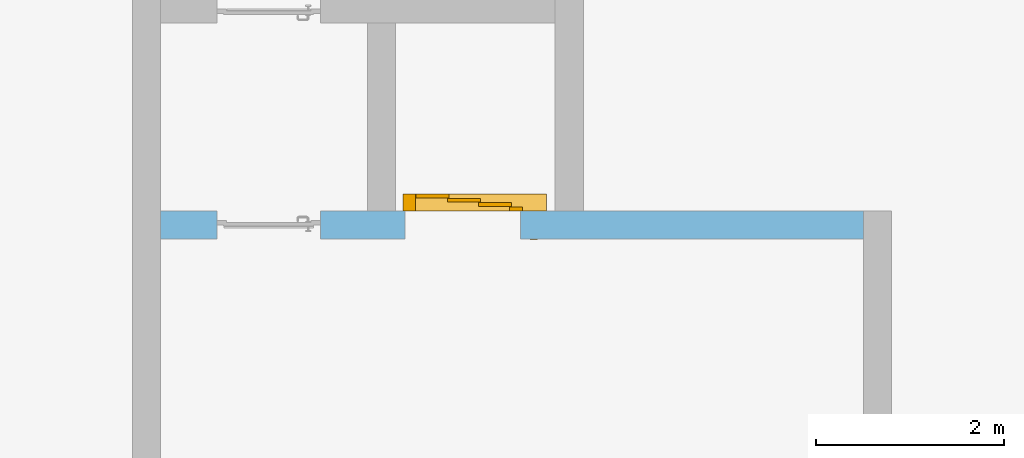
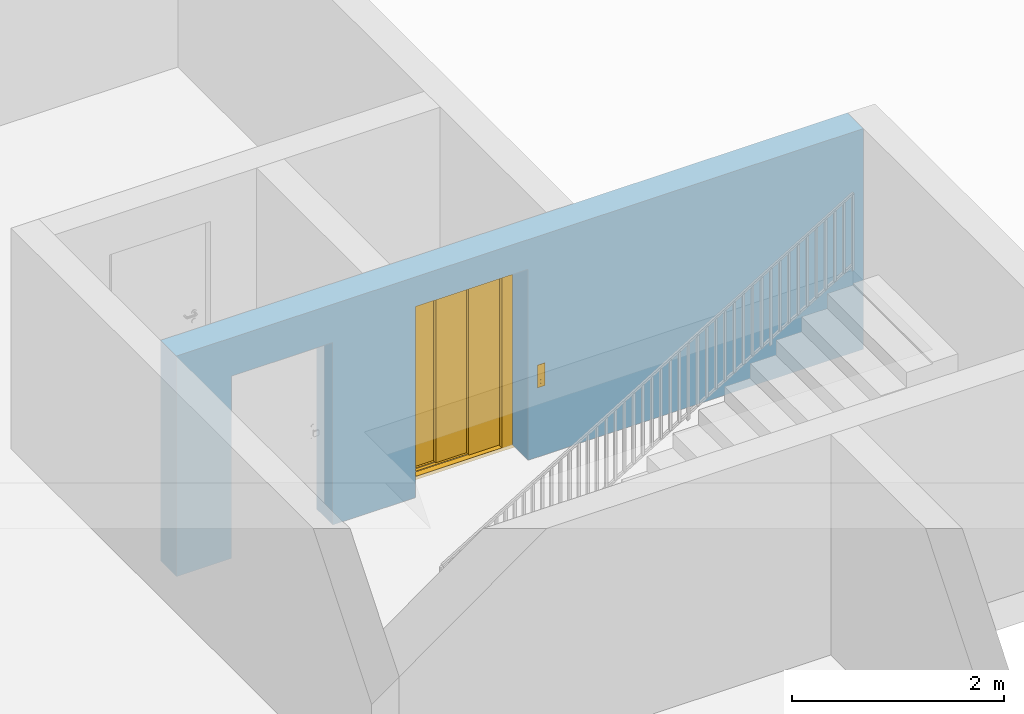
# One storey, part 4 of 6: 1 door, 2 openings, plus 1 element that does not belong to this part.
"""IFC4 building model written with IfcOpenShell, lengths in metres."""

from ifc_helpers import new_model, entity, si_unit, converted_unit, derived_unit, direction, frame, origin_with_axes, place, context, subcontext, project, spatial, polygons, source, transform, mapped, material, type_object, element, fill, save


model = new_model("IFC4")

# Units and contexts
model_context = context("Model", 3, precision=1e-05, world=origin_with_axes(), true_north=direction((0.0, 1.0)))
body_context = subcontext(model_context, "Body", "Model", "MODEL_VIEW")
ifc_project = project(units=[si_unit("LENGTHUNIT", "METRE"), si_unit("AREAUNIT", "SQUARE_METRE"), si_unit("VOLUMEUNIT", "CUBIC_METRE"), converted_unit("PLANEANGLEUNIT", "DEGREE", entity("IfcPlaneAngleMeasure", 0.0174532925199), si_unit("PLANEANGLEUNIT", "RADIAN"), dimensions=[0, 0, 0, 0, 0, 0, 0]), converted_unit("TIMEUNIT", "Year", entity("IfcTimeMeasure", 31556926.0), si_unit("TIMEUNIT", "SECOND"), dimensions=[0, 0, 1, 0, 0, 0, 0]), si_unit("MASSUNIT", "GRAM", prefix="KILO"), si_unit("THERMODYNAMICTEMPERATUREUNIT", "DEGREE_CELSIUS"), si_unit("LUMINOUSINTENSITYUNIT", "LUMEN"), si_unit("ENERGYUNIT", "JOULE", prefix="MEGA"), derived_unit("THERMALCONDUCTANCEUNIT", [(si_unit("POWERUNIT", "WATT"), 1), (si_unit("LENGTHUNIT", "METRE"), -1), (si_unit("THERMODYNAMICTEMPERATUREUNIT", "KELVIN"), -1)]), derived_unit("SPECIFICHEATCAPACITYUNIT", [(si_unit("ENERGYUNIT", "JOULE"), 1), (si_unit("MASSUNIT", "GRAM", prefix="KILO"), -1), (si_unit("THERMODYNAMICTEMPERATUREUNIT", "KELVIN"), -1)]), derived_unit("MASSDENSITYUNIT", [(si_unit("MASSUNIT", "GRAM", prefix="KILO"), 1), (si_unit("VOLUMEUNIT", "CUBIC_METRE"), -1)])], contexts=[model_context])

# Site, building, storey
site_placement = place(None, origin_with_axes())
site = spatial("IfcSite", under=ifc_project, at=site_placement, CompositionType="ELEMENT")
building_placement = place(site_placement, origin_with_axes())
building = spatial("IfcBuilding", under=site, at=building_placement, CompositionType="ELEMENT")
storey_placement = place(building_placement, frame((0.0, 0.0, -2.89), z_axis=(0.0, 0.0, 1.0), x_axis=(1.0, 0.0, 0.0)))
storey = spatial("IfcBuildingStorey", under=building, at=storey_placement, Name="-1. Geschoss", CompositionType="ELEMENT", Elevation=-2.89)

# Wall, openings, door
ifc_material = material()
wall_type = type_object("IfcWallType", Name="300", PredefinedType="NOTDEFINED")
wall_placement = place(storey_placement, frame((-5.2421993804, 1.37118776896, 0.0), z_axis=(0.0, 0.0, 1.0), x_axis=(1.0, 0.0, 0.0)))
wall = element("IfcWall", 1, at=wall_placement, inside=storey, type_object=wall_type, material=ifc_material, Name="Wand-001", PredefinedType="NOTDEFINED", context=body_context, shape_type="Tessellation", body=[
    polygons([(2.9, 0.3, 2.2), (2.9, 0.3, 0.0), (2.0, 0.3, 0.0), (2.0, 0.3, 2.1), (0.9, 0.3, 2.1), (0.9, 0.3, 0.0), (0.3, 0.3, 0.0), (0.3, 0.3, 2.54), (7.78, 0.3, 2.54), (7.78, 0.3, 0.0), (4.13, 0.3, 0.0), (4.13, 0.3, 2.2), (2.9, 0.0, 2.2), (2.9, 0.0, 0.0), (2.0, 0.0, 0.0), (2.0, 0.0, 2.1), (0.9, 0.0, 2.1), (0.9, 0.0, 0.0), (0.3, 0.0, 0.0), (0.3, 0.0, 2.54), (7.78, 0.0, 2.54), (7.78, 0.0, 0.0), (4.13, 0.0, 0.0), (4.13, 0.0, 2.2)], [[[1, 2, 3, 4, 5, 6, 7, 8, 9, 10, 11, 12]], [[2, 1, 13, 14]], [[2, 14, 15, 3]], [[3, 15, 16, 4]], [[4, 16, 17, 5]], [[5, 17, 18, 6]], [[18, 19, 7, 6]], [[7, 19, 20, 8]], [[8, 20, 21, 9]], [[22, 10, 9, 21]], [[23, 11, 10, 22]], [[12, 11, 23, 24]], [[1, 12, 24, 13]], [[24, 23, 22, 21, 20, 19, 18, 17, 16, 15, 14, 13]]], closed=True),
])
opening_1_placement = place(wall_placement, frame((1.45, 0.0, 0.0), z_axis=(0.0, 0.0, 1.0), x_axis=(1.0, 0.0, 0.0)))
element("IfcOpeningElement", 2, at=opening_1_placement, cuts=wall, context=body_context, identifier="Reference", shape_type="Tessellation", body=[
    polygons([(0.55, 0.15, 0.0), (0.55, 0.15, 2.1), (0.55, -0.001, 2.1), (0.55, -0.001, 0.0), (0.55, 0.301, 0.0), (0.55, 0.301, 2.1), (-0.55, 0.15, 2.1), (-0.55, -0.001, 2.1), (-0.55, 0.301, 2.1), (-0.55, -0.001, 0.0), (-0.55, 0.15, 0.0), (-0.55, 0.301, 0.0)], [[[1, 2, 3, 4]], [[2, 1, 5, 6]], [[7, 8, 3, 2, 6, 9]], [[8, 10, 4, 3]], [[1, 4, 10, 11, 12, 5]], [[6, 5, 12, 9]], [[7, 11, 10, 8]], [[11, 7, 9, 12]]], closed=True),
])
opening_2_placement = place(wall_placement, frame((3.515, 0.0, 0.0), z_axis=(0.0, 0.0, 1.0), x_axis=(1.0, 0.0, 0.0)))
opening_2 = element("IfcOpeningElement", 3, at=opening_2_placement, cuts=wall, context=body_context, identifier="Reference", shape_type="Tessellation", body=[
    polygons([(-0.615, -0.001, 2.2), (-0.615, -0.001, 0.0), (0.615, -0.001, 0.0), (0.615, -0.001, 2.2), (-0.615, 0.301, 2.2), (-0.615, 0.301, 0.0), (0.615, 0.301, 0.0), (0.615, 0.301, 2.2)], [[[1, 2, 3, 4]], [[5, 6, 2, 1]], [[6, 7, 3, 2]], [[7, 8, 4, 3]], [[8, 5, 1, 4]], [[7, 6, 5, 8]]], closed=True),
])
door_type = type_object("IfcDoorType", Name="26", OperationType="DOUBLE_DOOR_SLIDING", PredefinedType="DOOR")
shared_shape = source(origin_with_axes(), body_context, "Body", "Tessellation", [
    polygons([(0.891666666667, 0.135, 2.05), (-0.635, 0.135, 2.05), (-0.635, 0.135, 2.088), (0.891666666667, 0.135, 2.088), (0.891666666667, 0.0, 2.05), (-0.635, 0.0, 2.05), (-0.635, 0.0, 2.33), (-0.635, 0.18, 2.33), (-0.635, 0.18, 2.327), (-0.635, 0.003, 2.327), (-0.635, 0.003, 2.053), (-0.635, 0.132, 2.053), (-0.635, 0.132, 2.088), (0.891666666667, 0.132, 2.088), (0.891666666667, 0.132, 2.053), (0.891666666667, 0.003, 2.053), (0.891666666667, 0.003, 2.327), (0.891666666667, 0.18, 2.327), (0.891666666667, 0.18, 2.33), (0.891666666667, 0.0, 2.33)], [[[1, 2, 3, 4]], [[5, 6, 2, 1]], [[2, 6, 7, 8, 9, 10, 11, 12, 13, 3]], [[4, 3, 13, 14]], [[1, 4, 14, 15, 16, 17, 18, 19, 20, 5]], [[20, 7, 6, 5]], [[19, 8, 7, 20]], [[18, 9, 8, 19]], [[17, 10, 9, 18]], [[16, 11, 10, 17]], [[15, 12, 11, 16]], [[14, 13, 12, 15]]], closed=True),
    polygons([(0.891666666667, 0.05, 2.053), (-0.635, 0.05, 2.053), (-0.635, 0.055, 2.053), (0.891666666667, 0.055, 2.053), (0.891666666667, 0.05, 2.29), (-0.635, 0.05, 2.29), (-0.635, 0.055, 2.29), (0.891666666667, 0.055, 2.29)], [[[1, 2, 3, 4]], [[5, 6, 2, 1]], [[2, 6, 7, 3]], [[4, 3, 7, 8]], [[1, 4, 8, 5]], [[8, 7, 6, 5]]], closed=True),
    polygons([(0.891666666667, 0.05, 2.28), (-0.635, 0.05, 2.28), (-0.635, 0.04, 2.28), (0.891666666667, 0.04, 2.28), (0.891666666667, 0.05, 2.22), (-0.635, 0.05, 2.22), (-0.635, 0.04, 2.22), (0.891666666667, 0.04, 2.22)], [[[1, 2, 3, 4]], [[5, 6, 2, 1]], [[2, 6, 7, 3]], [[4, 3, 7, 8]], [[1, 4, 8, 5]], [[8, 7, 6, 5]]], closed=True),
    polygons([(0.891666666667, 0.05, 2.15), (-0.635, 0.05, 2.15), (-0.635, 0.04, 2.15), (0.891666666667, 0.04, 2.15), (0.891666666667, 0.05, 2.11), (-0.635, 0.05, 2.11), (-0.635, 0.04, 2.11), (0.891666666667, 0.04, 2.11)], [[[1, 2, 3, 4]], [[5, 6, 2, 1]], [[2, 6, 7, 3]], [[4, 3, 7, 8]], [[1, 4, 8, 5]], [[8, 7, 6, 5]]], closed=True),
    polygons([(0.891666666667, 0.05, 2.22), (-0.635, 0.05, 2.22), (-0.635, 0.03, 2.22), (0.891666666667, 0.03, 2.22), (0.891666666667, 0.05, 2.15), (-0.635, 0.05, 2.15), (-0.635, 0.03, 2.15), (0.891666666667, 0.03, 2.15)], [[[1, 2, 3, 4]], [[5, 6, 2, 1]], [[2, 6, 7, 3]], [[4, 3, 7, 8]], [[1, 4, 8, 5]], [[8, 7, 6, 5]]], closed=True),
    polygons([(0.891666666667, 0.095, 2.053), (-0.635, 0.095, 2.053), (-0.635, 0.1, 2.053), (0.891666666667, 0.1, 2.053), (0.891666666667, 0.095, 2.29), (-0.635, 0.095, 2.29), (-0.635, 0.1, 2.29), (0.891666666667, 0.1, 2.29)], [[[1, 2, 3, 4]], [[5, 6, 2, 1]], [[2, 6, 7, 3]], [[4, 3, 7, 8]], [[1, 4, 8, 5]], [[8, 7, 6, 5]]], closed=True),
    polygons([(0.891666666667, 0.095, 2.28), (-0.635, 0.095, 2.28), (-0.635, 0.085, 2.28), (0.891666666667, 0.085, 2.28), (0.891666666667, 0.095, 2.22), (-0.635, 0.095, 2.22), (-0.635, 0.085, 2.22), (0.891666666667, 0.085, 2.22)], [[[1, 2, 3, 4]], [[5, 6, 2, 1]], [[2, 6, 7, 3]], [[4, 3, 7, 8]], [[1, 4, 8, 5]], [[8, 7, 6, 5]]], closed=True),
    polygons([(0.891666666667, 0.095, 2.15), (-0.635, 0.095, 2.15), (-0.635, 0.085, 2.15), (0.891666666667, 0.085, 2.15), (0.891666666667, 0.095, 2.11), (-0.635, 0.095, 2.11), (-0.635, 0.085, 2.11), (0.891666666667, 0.085, 2.11)], [[[1, 2, 3, 4]], [[5, 6, 2, 1]], [[2, 6, 7, 3]], [[4, 3, 7, 8]], [[1, 4, 8, 5]], [[8, 7, 6, 5]]], closed=True),
    polygons([(0.891666666667, 0.095, 2.22), (-0.635, 0.095, 2.22), (-0.635, 0.075, 2.22), (0.891666666667, 0.075, 2.22), (0.891666666667, 0.095, 2.15), (-0.635, 0.095, 2.15), (-0.635, 0.075, 2.15), (0.891666666667, 0.075, 2.15)], [[[1, 2, 3, 4]], [[5, 6, 2, 1]], [[2, 6, 7, 3]], [[4, 3, 7, 8]], [[1, 4, 8, 5]], [[8, 7, 6, 5]]], closed=True),
    polygons([(0.891666666667, 0.14, 2.053), (-0.635, 0.14, 2.053), (-0.635, 0.145, 2.053), (0.891666666667, 0.145, 2.053), (0.891666666667, 0.14, 2.29), (-0.635, 0.14, 2.29), (-0.635, 0.145, 2.29), (0.891666666667, 0.145, 2.29)], [[[1, 2, 3, 4]], [[5, 6, 2, 1]], [[2, 6, 7, 3]], [[4, 3, 7, 8]], [[1, 4, 8, 5]], [[8, 7, 6, 5]]], closed=True),
    polygons([(0.891666666667, 0.14, 2.28), (-0.635, 0.14, 2.28), (-0.635, 0.13, 2.28), (0.891666666667, 0.13, 2.28), (0.891666666667, 0.14, 2.22), (-0.635, 0.14, 2.22), (-0.635, 0.13, 2.22), (0.891666666667, 0.13, 2.22)], [[[1, 2, 3, 4]], [[5, 6, 2, 1]], [[2, 6, 7, 3]], [[4, 3, 7, 8]], [[1, 4, 8, 5]], [[8, 7, 6, 5]]], closed=True),
    polygons([(0.891666666667, 0.14, 2.15), (-0.635, 0.14, 2.15), (-0.635, 0.13, 2.15), (0.891666666667, 0.13, 2.15), (0.891666666667, 0.14, 2.11), (-0.635, 0.14, 2.11), (-0.635, 0.13, 2.11), (0.891666666667, 0.13, 2.11)], [[[1, 2, 3, 4]], [[5, 6, 2, 1]], [[2, 6, 7, 3]], [[4, 3, 7, 8]], [[1, 4, 8, 5]], [[8, 7, 6, 5]]], closed=True),
    polygons([(0.891666666667, 0.14, 2.22), (-0.635, 0.14, 2.22), (-0.635, 0.12, 2.22), (0.891666666667, 0.12, 2.22), (0.891666666667, 0.14, 2.15), (-0.635, 0.14, 2.15), (-0.635, 0.12, 2.15), (0.891666666667, 0.12, 2.15)], [[[1, 2, 3, 4]], [[5, 6, 2, 1]], [[2, 6, 7, 3]], [[4, 3, 7, 8]], [[1, 4, 8, 5]], [[8, 7, 6, 5]]], closed=True),
    polygons([(0.891666666667, 0.0, 0.0), (-0.635, 0.0, 0.0), (-0.635, 0.0, -0.04), (0.891666666667, 0.0, -0.04), (0.891666666667, 0.065, 0.0), (-0.635, 0.065, 0.0), (-0.635, 0.065, -0.01), (-0.635, 0.075, -0.01), (-0.635, 0.075, 0.0), (-0.635, 0.11, 0.0), (-0.635, 0.11, -0.01), (-0.635, 0.12, -0.01), (-0.635, 0.12, 0.0), (-0.635, 0.155, 0.0), (-0.635, 0.155, -0.01), (-0.635, 0.165, -0.01), (-0.635, 0.165, 0.0), (-0.635, 0.18, 0.0), (-0.635, 0.18, -0.04), (0.891666666667, 0.18, -0.04), (0.891666666667, 0.18, 0.0), (0.891666666667, 0.165, 0.0), (0.891666666667, 0.165, -0.01), (0.891666666667, 0.155, -0.01), (0.891666666667, 0.155, 0.0), (0.891666666667, 0.12, 0.0), (0.891666666667, 0.12, -0.01), (0.891666666667, 0.11, -0.01), (0.891666666667, 0.11, 0.0), (0.891666666667, 0.075, 0.0), (0.891666666667, 0.075, -0.01), (0.891666666667, 0.065, -0.01)], [[[1, 2, 3, 4]], [[5, 6, 2, 1]], [[2, 6, 7, 8, 9, 10, 11, 12, 13, 14, 15, 16, 17, 18, 19, 3]], [[4, 3, 19, 20]], [[1, 4, 20, 21, 22, 23, 24, 25, 26, 27, 28, 29, 30, 31, 32, 5]], [[32, 7, 6, 5]], [[31, 8, 7, 32]], [[30, 9, 8, 31]], [[29, 10, 9, 30]], [[28, 11, 10, 29]], [[27, 12, 11, 28]], [[26, 13, 12, 27]], [[25, 14, 13, 26]], [[24, 15, 14, 25]], [[23, 16, 15, 24]], [[22, 17, 16, 23]], [[21, 18, 17, 22]], [[20, 19, 18, 21]]], closed=True),
    polygons([(0.5, 0.0, 0.0), (0.5, 0.0, 2.05), (0.5, 0.045, 2.05), (0.5, 0.045, 0.0), (0.635, 0.0, 0.0), (0.635, 0.0, 2.05), (0.635, 0.045, 2.05), (0.635, 0.045, 0.0)], [[[1, 2, 3, 4]], [[5, 6, 2, 1]], [[2, 6, 7, 3]], [[4, 3, 7, 8]], [[1, 4, 8, 5]], [[8, 7, 6, 5]]], closed=True),
    polygons([(-0.635, 0.0, 0.0), (-0.635, 0.0, 2.05), (-0.635, 0.18, 2.05), (-0.635, 0.18, 0.0), (-0.5, 0.0, 0.0), (-0.5, 0.0, 2.05), (-0.5, 0.18, 2.05), (-0.5, 0.18, 0.0)], [[[1, 2, 3, 4]], [[5, 6, 2, 1]], [[2, 6, 7, 3]], [[4, 3, 7, 8]], [[1, 4, 8, 5]], [[8, 7, 6, 5]]], closed=True),
    polygons([(0.715, -0.3, 0.8), (0.795, -0.3, 0.8), (0.795, -0.303, 0.8), (0.715, -0.303, 0.8), (0.715, -0.3, 1.06), (0.795, -0.3, 1.06), (0.725, -0.3, 1.03), (0.725, -0.3, 0.94), (0.785, -0.3, 0.94), (0.785, -0.3, 1.03), (0.745, -0.3, 0.84), (0.765, -0.3, 0.84), (0.765, -0.3, 0.86), (0.745, -0.3, 0.86), (0.745, -0.3, 0.88), (0.765, -0.3, 0.88), (0.765, -0.3, 0.9), (0.745, -0.3, 0.9), (0.795, -0.303, 1.06), (0.715, -0.303, 1.06), (0.725, -0.303, 1.03), (0.785, -0.303, 1.03), (0.785, -0.303, 0.94), (0.725, -0.303, 0.94), (0.745, -0.303, 0.84), (0.745, -0.303, 0.86), (0.765, -0.303, 0.86), (0.765, -0.303, 0.84), (0.745, -0.303, 0.88), (0.745, -0.303, 0.9), (0.765, -0.303, 0.9), (0.765, -0.303, 0.88)], [[[1, 2, 3, 4]], [[1, 5, 6, 2], [7, 8, 9, 10], [11, 12, 13, 14], [15, 16, 17, 18]], [[2, 6, 19, 3]], [[4, 3, 19, 20], [21, 22, 23, 24], [25, 26, 27, 28], [29, 30, 31, 32]], [[5, 1, 4, 20]], [[6, 5, 20, 19]], [[8, 7, 21, 24]], [[9, 8, 24, 23]], [[10, 9, 23, 22]], [[7, 10, 22, 21]], [[12, 11, 25, 28]], [[13, 12, 28, 27]], [[14, 13, 27, 26]], [[11, 14, 26, 25]], [[16, 15, 29, 32]], [[17, 16, 32, 31]], [[18, 17, 31, 30]], [[15, 18, 30, 29]]], closed=True),
    polygons([(0.725, -0.3, 0.94), (0.785, -0.3, 0.94), (0.785, -0.3025, 0.94), (0.725, -0.3025, 0.94), (0.725, -0.3, 1.03), (0.785, -0.3, 1.03), (0.785, -0.3025, 1.03), (0.725, -0.3025, 1.03)], [[[1, 2, 3, 4]], [[1, 5, 6, 2]], [[2, 6, 7, 3]], [[4, 3, 7, 8]], [[5, 1, 4, 8]], [[6, 5, 8, 7]]], closed=True),
    polygons([(0.739, -0.303, 1.005), (0.745, -0.303, 1.021), (0.751, -0.303, 1.005)], [[[1, 2, 3]]], closed=False),
    polygons([(0.765, -0.303, 1.005), (0.759, -0.303, 1.021), (0.771, -0.303, 1.021)], [[[1, 2, 3]]], closed=False),
    polygons([(0.752272727273, -0.3035, 0.982), (0.752272727273, -0.3035, 0.971636363636), (0.750909090909, -0.3035, 0.970272727273), (0.749545454545, -0.3035, 0.971636363636), (0.749545454545, -0.3035, 0.982), (0.750909090909, -0.3035, 0.983363636364)], [[[1, 2, 3, 4, 5, 6]]], closed=False),
    polygons([(0.752272727273, -0.3035, 0.968363636364), (0.752272727273, -0.3035, 0.958), (0.750909090909, -0.3035, 0.956636363636), (0.749545454545, -0.3035, 0.958), (0.749545454545, -0.3035, 0.968363636364), (0.750909090909, -0.3035, 0.969727272727)], [[[1, 2, 3, 4, 5, 6]]], closed=False),
    polygons([(0.771090909091, -0.3035, 0.982272727273), (0.760727272727, -0.3035, 0.982272727273), (0.759363636364, -0.3035, 0.983636363636), (0.760727272727, -0.3035, 0.985), (0.771090909091, -0.3035, 0.985), (0.772454545455, -0.3035, 0.983636363636)], [[[1, 2, 3, 4, 5, 6]]], closed=False),
    polygons([(0.774090909091, -0.3035, 0.982), (0.774090909091, -0.3035, 0.971636363636), (0.772727272727, -0.3035, 0.970272727273), (0.771363636364, -0.3035, 0.971636363636), (0.771363636364, -0.3035, 0.982), (0.772727272727, -0.3035, 0.983363636364)], [[[1, 2, 3, 4, 5, 6]]], closed=False),
    polygons([(0.771090909091, -0.3035, 0.968636363636), (0.760727272727, -0.3035, 0.968636363636), (0.759363636364, -0.3035, 0.97), (0.760727272727, -0.3035, 0.971363636364), (0.771090909091, -0.3035, 0.971363636364), (0.772454545455, -0.3035, 0.97)], [[[1, 2, 3, 4, 5, 6]]], closed=False),
    polygons([(0.760454545455, -0.3035, 0.968363636364), (0.760454545455, -0.3035, 0.958), (0.759090909091, -0.3035, 0.956636363636), (0.757727272727, -0.3035, 0.958), (0.757727272727, -0.3035, 0.968363636364), (0.759090909091, -0.3035, 0.969727272727)], [[[1, 2, 3, 4, 5, 6]]], closed=False),
    polygons([(0.771090909091, -0.3035, 0.955), (0.760727272727, -0.3035, 0.955), (0.759363636364, -0.3035, 0.956363636364), (0.760727272727, -0.3035, 0.957727272727), (0.771090909091, -0.3035, 0.957727272727), (0.772454545455, -0.3035, 0.956363636364)], [[[1, 2, 3, 4, 5, 6]]], closed=False),
    polygons([(0.765, -0.3, 0.84), (0.745, -0.3, 0.84), (0.745, -0.3, 0.86), (0.765, -0.3, 0.86), (0.765000000095, -0.3015, 0.83999999961), (0.74499999961, -0.3015, 0.83999999961), (0.74499999961, -0.3015, 0.860000000095), (0.765000000095, -0.3015, 0.860000000095), (0.763599999679, -0.302900000416, 0.841400000026), (0.746400000026, -0.302900000416, 0.841400000026), (0.746400000026, -0.302900000416, 0.858599999679), (0.763599999679, -0.302900000416, 0.858599999679)], [[[1, 2, 3, 4]], [[2, 1, 5, 6]], [[3, 2, 6, 7]], [[4, 3, 7, 8]], [[1, 4, 8, 5]], [[6, 5, 9, 10]], [[7, 6, 10, 11]], [[8, 7, 11, 12]], [[5, 8, 12, 9]], [[11, 10, 9, 12]]], closed=True),
    polygons([(0.76, -0.303, 0.855), (0.755, -0.303, 0.844), (0.75, -0.303, 0.855)], [[[1, 2, 3]]], closed=False),
    polygons([(0.765, -0.3, 0.88), (0.745, -0.3, 0.88), (0.745, -0.3, 0.9), (0.765, -0.3, 0.9), (0.765000000095, -0.3015, 0.87999999961), (0.74499999961, -0.3015, 0.87999999961), (0.74499999961, -0.3015, 0.900000000095), (0.765000000095, -0.3015, 0.900000000095), (0.763599999679, -0.302900000416, 0.881400000026), (0.746400000026, -0.302900000416, 0.881400000026), (0.746400000026, -0.302900000416, 0.898599999679), (0.763599999679, -0.302900000416, 0.898599999679)], [[[1, 2, 3, 4]], [[2, 1, 5, 6]], [[3, 2, 6, 7]], [[4, 3, 7, 8]], [[1, 4, 8, 5]], [[6, 5, 9, 10]], [[7, 6, 10, 11]], [[8, 7, 11, 12]], [[5, 8, 12, 9]], [[11, 10, 9, 12]]], closed=True),
    polygons([(0.76, -0.303, 0.885), (0.75, -0.303, 0.885), (0.755, -0.303, 0.896)], [[[1, 2, 3]]], closed=False),
    polygons([(-0.143333333333, 0.14, 0.003), (-0.495, 0.14, 0.003), (-0.495, 0.18, 0.003), (-0.143333333333, 0.18, 0.003), (-0.143333333333, 0.14, 2.05), (-0.495, 0.14, 2.05), (-0.495, 0.18, 2.05), (-0.143333333333, 0.18, 2.05)], [[[1, 2, 3, 4]], [[1, 5, 6, 2]], [[2, 6, 7, 3]], [[4, 3, 7, 8]], [[5, 1, 4, 8]], [[6, 5, 8, 7]]], closed=True),
    polygons([(0.188333333333, 0.095, 0.003), (-0.163333333333, 0.095, 0.003), (-0.163333333333, 0.135, 0.003), (0.188333333333, 0.135, 0.003), (0.188333333333, 0.095, 2.05), (-0.163333333333, 0.095, 2.05), (-0.163333333333, 0.135, 2.05), (0.188333333333, 0.135, 2.05)], [[[1, 2, 3, 4]], [[1, 5, 6, 2]], [[2, 6, 7, 3]], [[4, 3, 7, 8]], [[5, 1, 4, 8]], [[6, 5, 8, 7]]], closed=True),
    polygons([(0.52, 0.05, 0.003), (0.168333333333, 0.05, 0.003), (0.168333333333, 0.09, 0.003), (0.52, 0.09, 0.003), (0.52, 0.05, 2.05), (0.168333333333, 0.05, 2.05), (0.168333333333, 0.09, 2.05), (0.52, 0.09, 2.05)], [[[1, 2, 3, 4]], [[1, 5, 6, 2]], [[2, 6, 7, 3]], [[4, 3, 7, 8]], [[5, 1, 4, 8]], [[6, 5, 8, 7]]], closed=True),
])
door_placement = place(opening_2_placement, frame((-0.5, 0.0, 0.0), z_axis=(0.0, 0.0, 1.0), x_axis=(1.0, 0.0, 0.0)))
door = element("IfcDoor", 4, at=door_placement, inside=storey, type_object=door_type, OverallHeight=2.2, OverallWidth=1.23, PredefinedType="DOOR", context=body_context, shape_type="MappedRepresentation", body=[
    mapped(shared_shape, transform((0.5, 0.3, 0.0))),
])
fill(opening_2, door)

save(model, "model.ifc")
